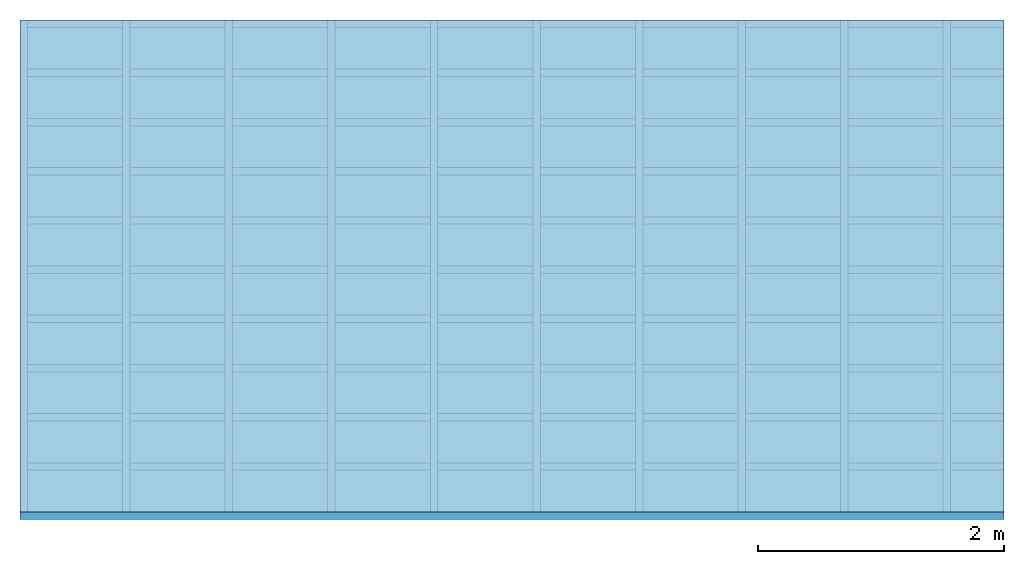
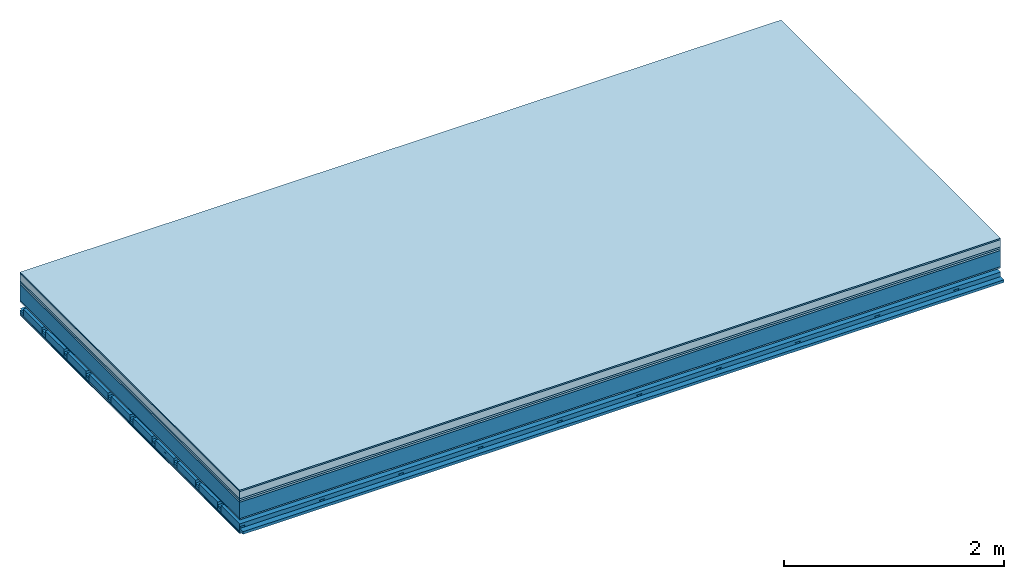
# One storey: 8 plates, 4 members, 1 element without a shape of its own.
"""IFC4 building model written with IfcOpenShell, lengths in metres."""

from ifc_helpers import new_model, si_unit, derived_unit, direction, frame, frame_2d, origin, origin_with_axes, place, context, project, spatial, polyline, rectangle, outline, extrude, material, layer, layer_set, type_object, element, aggregate, save


model = new_model("IFC4")

# Units and contexts
plan_context = context("Plan", 3, precision=1e-05, world=origin(), true_north=direction((0.0, 1.0)))
model_context = context("Model", 3, precision=1e-05, world=origin(), true_north=direction((0.0, 1.0)))
ifc_project = project(units=[si_unit("LENGTHUNIT", "METRE"), derived_unit("SOUNDPRESSUREUNIT", [(si_unit("PRESSUREUNIT", "PASCAL", prefix="MICRO"), 0)]), si_unit("ENERGYUNIT", "JOULE", prefix="MEGA"), si_unit("MASSUNIT", "GRAM", prefix="KILO"), derived_unit("THERMALTRANSMITTANCEUNIT", [(si_unit("POWERUNIT", "WATT"), 1), (si_unit("AREAUNIT", "SQUARE_METRE"), -1), (si_unit("THERMODYNAMICTEMPERATUREUNIT", "KELVIN"), -1)]), derived_unit("AREADENSITYUNIT", [(si_unit("MASSUNIT", "GRAM", prefix="KILO"), 1), (si_unit("AREAUNIT", "SQUARE_METRE"), -1)]), derived_unit("USERDEFINED", [(si_unit("ENERGYUNIT", "JOULE", prefix="MEGA"), 1), (si_unit("AREAUNIT", "SQUARE_METRE"), -1)])], contexts=[plan_context, model_context])

# Site, building, storey
site = spatial("IfcSite", under=ifc_project)
building_placement = place(None, origin())
building = spatial("IfcBuilding", under=site, at=building_placement)
storey_placement = place(building_placement, origin())
storey = spatial("IfcBuildingStorey", under=building, at=storey_placement)

# Slab, members, plates
ifc_material_1 = material(Category="11.013")
ifc_layer_1 = layer(ifc_material_1, 0.015, Name="Flooring")
ifc_material_2 = material(Name="Cement screed", Category="04.006")
ifc_layer_2 = layer(ifc_material_2, 0.08, Name="On-material")
ifc_material_3 = material(Name="Wood fiber generic product", Category="10.009")
ifc_layer_3 = layer(ifc_material_3, 0.02, Name="Impact sound insulation")
ifc_material_4 = material(Category="10.004")
ifc_layer_4 = layer(ifc_material_4, 0.02, Name="Additional insulation")
ifc_material_5 = material(Name="no composite action")
ifc_layer_5 = layer(ifc_material_5, 0.0, Name="Bond")
ifc_layer_6 = layer(None, 0.18, Name="Supporting structure")
ifc_material_6 = material(Name="of the art")
ifc_layer_7 = layer(ifc_material_6, 0.0, Name="Bond")
ifc_material_7 = material(Category="03.007")
ifc_layer_8 = layer(ifc_material_7, 0.015, Name="Lower layer 1")
ifc_layer_9 = layer(None, 0.095, Name="Coupling")
ifc_layer_10 = layer(None, 0.03, Name="Battens / profiles")
ifc_material_8 = material(Name="Plasterboard type A", Category="03.008")
ifc_layer_11 = layer(ifc_material_8, 0.0125, Name="Ceiling covering 1st layer")
ifc_layer_12 = layer(ifc_material_8, 0.0125, Name="Ceiling covering layer 2")
ifc_material_9 = material(Category="04.001")
ifc_layer_13 = layer(ifc_material_9, 0.003, Name="Surface / treatment")
ifc_layer_set = layer_set([ifc_layer_1, ifc_layer_2, ifc_layer_3, ifc_layer_4, ifc_layer_5, ifc_layer_6, ifc_layer_7, ifc_layer_8, ifc_layer_9, ifc_layer_10, ifc_layer_11, ifc_layer_12, ifc_layer_13])
slab_type = type_object("IfcSlabType", Name="A2162", PredefinedType="NOTDEFINED", material=ifc_layer_set)
slab_placement = place(None, frame((0.0, 0.0, 0.0), z_axis=(0.0, 0.0, -1.0), x_axis=(1.0, 0.0, 0.0)))
slab = element("IfcSlab", 1, at=slab_placement, inside=storey, type_object=slab_type, material=ifc_layer_set, Name="Slab #1")
ifc_material_10 = material(Name="Solid timber panel")
member_1_placement = place(slab_placement, origin())
member_1 = element("IfcMember", 2, at=member_1_placement, material=ifc_material_10, Name="Supporting structure", context=plan_context, shape_type="SweptSolid", body=[
    extrude(rectangle(XDim=1.0, YDim=0.18, at=frame_2d((0.5, 0.09), x_axis=(1.0, 0.0))), frame((0.0, 4.0, 0.135), z_axis=(0.0, -1.0, 0.0), x_axis=(1.0, 0.0, 0.0)), (0.0, 0.0, 1.0), 4.0),
    extrude(rectangle(XDim=1.0, YDim=0.18, at=frame_2d((0.5, 0.09), x_axis=(1.0, 0.0))), frame((1.0, 4.0, 0.135), z_axis=(0.0, -1.0, 0.0), x_axis=(1.0, 0.0, 0.0)), (0.0, 0.0, 1.0), 4.0),
    extrude(rectangle(XDim=1.0, YDim=0.18, at=frame_2d((0.5, 0.09), x_axis=(1.0, 0.0))), frame((2.0, 4.0, 0.135), z_axis=(0.0, -1.0, 0.0), x_axis=(1.0, 0.0, 0.0)), (0.0, 0.0, 1.0), 4.0),
    extrude(rectangle(XDim=1.0, YDim=0.18, at=frame_2d((0.5, 0.09), x_axis=(1.0, 0.0))), frame((3.0, 4.0, 0.135), z_axis=(0.0, -1.0, 0.0), x_axis=(1.0, 0.0, 0.0)), (0.0, 0.0, 1.0), 4.0),
    extrude(rectangle(XDim=1.0, YDim=0.18, at=frame_2d((0.5, 0.09), x_axis=(1.0, 0.0))), frame((4.0, 4.0, 0.135), z_axis=(0.0, -1.0, 0.0), x_axis=(1.0, 0.0, 0.0)), (0.0, 0.0, 1.0), 4.0),
    extrude(rectangle(XDim=1.0, YDim=0.18, at=frame_2d((0.5, 0.09), x_axis=(1.0, 0.0))), frame((5.0, 4.0, 0.135), z_axis=(0.0, -1.0, 0.0), x_axis=(1.0, 0.0, 0.0)), (0.0, 0.0, 1.0), 4.0),
    extrude(rectangle(XDim=1.0, YDim=0.18, at=frame_2d((0.5, 0.09), x_axis=(1.0, 0.0))), frame((6.0, 4.0, 0.135), z_axis=(0.0, -1.0, 0.0), x_axis=(1.0, 0.0, 0.0)), (0.0, 0.0, 1.0), 4.0),
    extrude(rectangle(XDim=1.0, YDim=0.18, at=frame_2d((0.5, 0.09), x_axis=(1.0, 0.0))), frame((7.0, 4.0, 0.135), z_axis=(0.0, -1.0, 0.0), x_axis=(1.0, 0.0, 0.0)), (0.0, 0.0, 1.0), 4.0),
])
ifc_material_11 = material()
member_2_placement = place(slab_placement, origin())
member_2 = element("IfcMember", 3, at=member_2_placement, material=ifc_material_11, Name="Coupling", context=plan_context, shape_type="SweptSolid", body=[
    extrude(outline(polyline([(0.0, 0.0), (0.06, 0.0), (0.04, 0.02), (0.02, 0.02), (0.0, 0.0)])), frame((0.0, 4.0, 0.405), z_axis=(0.0, -1.0, 0.0), x_axis=(1.0, 0.0, 0.0)), (0.0, 0.0, 1.0), 4.0),
    extrude(outline(polyline([(0.0, 0.0), (0.06, 0.0), (0.04, 0.02), (0.02, 0.02), (0.0, 0.0)])), frame((0.834, 4.0, 0.405), z_axis=(0.0, -1.0, 0.0), x_axis=(1.0, 0.0, 0.0)), (0.0, 0.0, 1.0), 4.0),
    extrude(outline(polyline([(0.0, 0.0), (0.06, 0.0), (0.04, 0.02), (0.02, 0.02), (0.0, 0.0)])), frame((1.668, 4.0, 0.405), z_axis=(0.0, -1.0, 0.0), x_axis=(1.0, 0.0, 0.0)), (0.0, 0.0, 1.0), 4.0),
    extrude(outline(polyline([(0.0, 0.0), (0.06, 0.0), (0.04, 0.02), (0.02, 0.02), (0.0, 0.0)])), frame((2.502, 4.0, 0.405), z_axis=(0.0, -1.0, 0.0), x_axis=(1.0, 0.0, 0.0)), (0.0, 0.0, 1.0), 4.0),
    extrude(outline(polyline([(0.0, 0.0), (0.06, 0.0), (0.04, 0.02), (0.02, 0.02), (0.0, 0.0)])), frame((3.336, 4.0, 0.405), z_axis=(0.0, -1.0, 0.0), x_axis=(1.0, 0.0, 0.0)), (0.0, 0.0, 1.0), 4.0),
    extrude(outline(polyline([(0.0, 0.0), (0.06, 0.0), (0.04, 0.02), (0.02, 0.02), (0.0, 0.0)])), frame((4.17, 4.0, 0.405), z_axis=(0.0, -1.0, 0.0), x_axis=(1.0, 0.0, 0.0)), (0.0, 0.0, 1.0), 4.0),
    extrude(outline(polyline([(0.0, 0.0), (0.06, 0.0), (0.04, 0.02), (0.02, 0.02), (0.0, 0.0)])), frame((5.004, 4.0, 0.405), z_axis=(0.0, -1.0, 0.0), x_axis=(1.0, 0.0, 0.0)), (0.0, 0.0, 1.0), 4.0),
    extrude(outline(polyline([(0.0, 0.0), (0.06, 0.0), (0.04, 0.02), (0.02, 0.02), (0.0, 0.0)])), frame((5.838, 4.0, 0.405), z_axis=(0.0, -1.0, 0.0), x_axis=(1.0, 0.0, 0.0)), (0.0, 0.0, 1.0), 4.0),
    extrude(outline(polyline([(0.0, 0.0), (0.06, 0.0), (0.04, 0.02), (0.02, 0.02), (0.0, 0.0)])), frame((6.672, 4.0, 0.405), z_axis=(0.0, -1.0, 0.0), x_axis=(1.0, 0.0, 0.0)), (0.0, 0.0, 1.0), 4.0),
    extrude(outline(polyline([(0.0, 0.0), (0.06, 0.0), (0.04, 0.02), (0.02, 0.02), (0.0, 0.0)])), frame((7.506, 4.0, 0.405), z_axis=(0.0, -1.0, 0.0), x_axis=(1.0, 0.0, 0.0)), (0.0, 0.0, 1.0), 4.0),
])
member_3_placement = place(slab_placement, origin())
member_3 = element("IfcMember", 4, at=member_3_placement, material=ifc_material_11, Name="Battens / profiles", context=plan_context, shape_type="SweptSolid", body=[
    extrude(rectangle(XDim=0.06, YDim=0.03, at=frame_2d((0.03, 0.015), x_axis=(1.0, 0.0))), frame((0.0, 0.0, 0.425), z_axis=(1.0, 0.0, 0.0), x_axis=(0.0, 1.0, 0.0)), (0.0, 0.0, 1.0), 8.0),
    extrude(rectangle(XDim=0.06, YDim=0.03, at=frame_2d((0.03, 0.015), x_axis=(1.0, 0.0))), frame((0.0, 0.4, 0.425), z_axis=(1.0, 0.0, 0.0), x_axis=(0.0, 1.0, 0.0)), (0.0, 0.0, 1.0), 8.0),
    extrude(rectangle(XDim=0.06, YDim=0.03, at=frame_2d((0.03, 0.015), x_axis=(1.0, 0.0))), frame((0.0, 0.8, 0.425), z_axis=(1.0, 0.0, 0.0), x_axis=(0.0, 1.0, 0.0)), (0.0, 0.0, 1.0), 8.0),
    extrude(rectangle(XDim=0.06, YDim=0.03, at=frame_2d((0.03, 0.015), x_axis=(1.0, 0.0))), frame((0.0, 1.2, 0.425), z_axis=(1.0, 0.0, 0.0), x_axis=(0.0, 1.0, 0.0)), (0.0, 0.0, 1.0), 8.0),
    extrude(rectangle(XDim=0.06, YDim=0.03, at=frame_2d((0.03, 0.015), x_axis=(1.0, 0.0))), frame((0.0, 1.6, 0.425), z_axis=(1.0, 0.0, 0.0), x_axis=(0.0, 1.0, 0.0)), (0.0, 0.0, 1.0), 8.0),
    extrude(rectangle(XDim=0.06, YDim=0.03, at=frame_2d((0.03, 0.015), x_axis=(1.0, 0.0))), frame((0.0, 2.0, 0.425), z_axis=(1.0, 0.0, 0.0), x_axis=(0.0, 1.0, 0.0)), (0.0, 0.0, 1.0), 8.0),
    extrude(rectangle(XDim=0.06, YDim=0.03, at=frame_2d((0.03, 0.015), x_axis=(1.0, 0.0))), frame((0.0, 2.4, 0.425), z_axis=(1.0, 0.0, 0.0), x_axis=(0.0, 1.0, 0.0)), (0.0, 0.0, 1.0), 8.0),
    extrude(rectangle(XDim=0.06, YDim=0.03, at=frame_2d((0.03, 0.015), x_axis=(1.0, 0.0))), frame((0.0, 2.8, 0.425), z_axis=(1.0, 0.0, 0.0), x_axis=(0.0, 1.0, 0.0)), (0.0, 0.0, 1.0), 8.0),
    extrude(rectangle(XDim=0.06, YDim=0.03, at=frame_2d((0.03, 0.015), x_axis=(1.0, 0.0))), frame((0.0, 3.2, 0.425), z_axis=(1.0, 0.0, 0.0), x_axis=(0.0, 1.0, 0.0)), (0.0, 0.0, 1.0), 8.0),
    extrude(rectangle(XDim=0.06, YDim=0.03, at=frame_2d((0.03, 0.015), x_axis=(1.0, 0.0))), frame((0.0, 3.6, 0.425), z_axis=(1.0, 0.0, 0.0), x_axis=(0.0, 1.0, 0.0)), (0.0, 0.0, 1.0), 8.0),
    extrude(rectangle(XDim=0.06, YDim=0.03, at=frame_2d((0.03, 0.015), x_axis=(1.0, 0.0))), frame((0.0, 4.0, 0.425), z_axis=(1.0, 0.0, 0.0), x_axis=(0.0, 1.0, 0.0)), (0.0, 0.0, 1.0), 8.0),
])
ifc_material_12 = material()
member_4_placement = place(slab_placement, origin())
member_4 = element("IfcMember", 5, at=member_4_placement, material=ifc_material_12, Name="Cavity", context=plan_context, shape_type="SweptSolid", body=[
    extrude(rectangle(XDim=0.34, YDim=0.08, at=frame_2d((0.17, 0.04), x_axis=(1.0, 0.0))), frame((0.0, 0.06, 0.375), z_axis=(1.0, 0.0, 0.0), x_axis=(0.0, 1.0, 0.0)), (0.0, 0.0, 1.0), 8.0),
    extrude(rectangle(XDim=0.34, YDim=0.08, at=frame_2d((0.17, 0.04), x_axis=(1.0, 0.0))), frame((0.0, 0.46, 0.375), z_axis=(1.0, 0.0, 0.0), x_axis=(0.0, 1.0, 0.0)), (0.0, 0.0, 1.0), 8.0),
    extrude(rectangle(XDim=0.34, YDim=0.08, at=frame_2d((0.17, 0.04), x_axis=(1.0, 0.0))), frame((0.0, 0.86, 0.375), z_axis=(1.0, 0.0, 0.0), x_axis=(0.0, 1.0, 0.0)), (0.0, 0.0, 1.0), 8.0),
    extrude(rectangle(XDim=0.34, YDim=0.08, at=frame_2d((0.17, 0.04), x_axis=(1.0, 0.0))), frame((0.0, 1.26, 0.375), z_axis=(1.0, 0.0, 0.0), x_axis=(0.0, 1.0, 0.0)), (0.0, 0.0, 1.0), 8.0),
    extrude(rectangle(XDim=0.34, YDim=0.08, at=frame_2d((0.17, 0.04), x_axis=(1.0, 0.0))), frame((0.0, 1.66, 0.375), z_axis=(1.0, 0.0, 0.0), x_axis=(0.0, 1.0, 0.0)), (0.0, 0.0, 1.0), 8.0),
    extrude(rectangle(XDim=0.34, YDim=0.08, at=frame_2d((0.17, 0.04), x_axis=(1.0, 0.0))), frame((0.0, 2.06, 0.375), z_axis=(1.0, 0.0, 0.0), x_axis=(0.0, 1.0, 0.0)), (0.0, 0.0, 1.0), 8.0),
    extrude(rectangle(XDim=0.34, YDim=0.08, at=frame_2d((0.17, 0.04), x_axis=(1.0, 0.0))), frame((0.0, 2.46, 0.375), z_axis=(1.0, 0.0, 0.0), x_axis=(0.0, 1.0, 0.0)), (0.0, 0.0, 1.0), 8.0),
    extrude(rectangle(XDim=0.34, YDim=0.08, at=frame_2d((0.17, 0.04), x_axis=(1.0, 0.0))), frame((0.0, 2.86, 0.375), z_axis=(1.0, 0.0, 0.0), x_axis=(0.0, 1.0, 0.0)), (0.0, 0.0, 1.0), 8.0),
    extrude(rectangle(XDim=0.34, YDim=0.08, at=frame_2d((0.17, 0.04), x_axis=(1.0, 0.0))), frame((0.0, 3.26, 0.375), z_axis=(1.0, 0.0, 0.0), x_axis=(0.0, 1.0, 0.0)), (0.0, 0.0, 1.0), 8.0),
    extrude(rectangle(XDim=0.34, YDim=0.08, at=frame_2d((0.17, 0.04), x_axis=(1.0, 0.0))), frame((0.0, 3.66, 0.375), z_axis=(1.0, 0.0, 0.0), x_axis=(0.0, 1.0, 0.0)), (0.0, 0.0, 1.0), 8.0),
])
plate_1_placement = place(slab_placement, origin())
plate_1 = element("IfcPlate", 6, at=plate_1_placement, material=ifc_material_1, Name="Flooring", context=plan_context, shape_type="SweptSolid", body=[
    extrude(rectangle(XDim=8.0, YDim=4.0, at=frame_2d((4.0, 2.0), x_axis=(1.0, 0.0))), origin_with_axes(), (0.0, 0.0, 1.0), 0.015),
])
plate_2_placement = place(slab_placement, origin())
plate_2 = element("IfcPlate", 7, at=plate_2_placement, material=ifc_material_2, Name="On-material", context=plan_context, shape_type="SweptSolid", body=[
    extrude(rectangle(XDim=8.0, YDim=4.0, at=frame_2d((4.0, 2.0), x_axis=(1.0, 0.0))), frame((0.0, 0.0, 0.015), z_axis=(0.0, 0.0, 1.0), x_axis=(1.0, 0.0, 0.0)), (0.0, 0.0, 1.0), 0.08),
])
plate_3_placement = place(slab_placement, origin())
plate_3 = element("IfcPlate", 8, at=plate_3_placement, material=ifc_material_3, Name="Impact sound insulation", context=plan_context, shape_type="SweptSolid", body=[
    extrude(rectangle(XDim=8.0, YDim=4.0, at=frame_2d((4.0, 2.0), x_axis=(1.0, 0.0))), frame((0.0, 0.0, 0.095), z_axis=(0.0, 0.0, 1.0), x_axis=(1.0, 0.0, 0.0)), (0.0, 0.0, 1.0), 0.02),
])
plate_4_placement = place(slab_placement, origin())
plate_4 = element("IfcPlate", 9, at=plate_4_placement, material=ifc_material_4, Name="Additional insulation", context=plan_context, shape_type="SweptSolid", body=[
    extrude(rectangle(XDim=8.0, YDim=4.0, at=frame_2d((4.0, 2.0), x_axis=(1.0, 0.0))), frame((0.0, 0.0, 0.115), z_axis=(0.0, 0.0, 1.0), x_axis=(1.0, 0.0, 0.0)), (0.0, 0.0, 1.0), 0.02),
])
plate_5_placement = place(slab_placement, origin())
plate_5 = element("IfcPlate", 10, at=plate_5_placement, material=ifc_material_7, Name="Lower layer 1", context=plan_context, shape_type="SweptSolid", body=[
    extrude(rectangle(XDim=8.0, YDim=4.0, at=frame_2d((4.0, 2.0), x_axis=(1.0, 0.0))), frame((0.0, 0.0, 0.315), z_axis=(0.0, 0.0, 1.0), x_axis=(1.0, 0.0, 0.0)), (0.0, 0.0, 1.0), 0.015),
])
plate_6_placement = place(slab_placement, origin())
plate_6 = element("IfcPlate", 11, at=plate_6_placement, material=ifc_material_8, Name="Ceiling covering 1st layer", context=plan_context, shape_type="SweptSolid", body=[
    extrude(rectangle(XDim=8.0, YDim=4.0, at=frame_2d((4.0, 2.0), x_axis=(1.0, 0.0))), frame((0.0, 0.0, 0.455), z_axis=(0.0, 0.0, 1.0), x_axis=(1.0, 0.0, 0.0)), (0.0, 0.0, 1.0), 0.0125),
])
plate_7_placement = place(slab_placement, origin())
plate_7 = element("IfcPlate", 12, at=plate_7_placement, material=ifc_material_8, Name="Ceiling covering layer 2", context=plan_context, shape_type="SweptSolid", body=[
    extrude(rectangle(XDim=8.0, YDim=4.0, at=frame_2d((4.0, 2.0), x_axis=(1.0, 0.0))), frame((0.0, 0.0, 0.4675), z_axis=(0.0, 0.0, 1.0), x_axis=(1.0, 0.0, 0.0)), (0.0, 0.0, 1.0), 0.0125),
])
plate_8_placement = place(slab_placement, origin())
plate_8 = element("IfcPlate", 13, at=plate_8_placement, material=ifc_material_9, Name="Surface / treatment", context=plan_context, shape_type="SweptSolid", body=[
    extrude(rectangle(XDim=8.0, YDim=4.0, at=frame_2d((4.0, 2.0), x_axis=(1.0, 0.0))), frame((0.0, 0.0, 0.48), z_axis=(0.0, 0.0, 1.0), x_axis=(1.0, 0.0, 0.0)), (0.0, 0.0, 1.0), 0.003),
])
aggregate(slab, [plate_1, plate_2, plate_3, plate_4, member_1, plate_5, member_2, member_3, member_4, plate_6, plate_7, plate_8])

save(model, "model.ifc")
